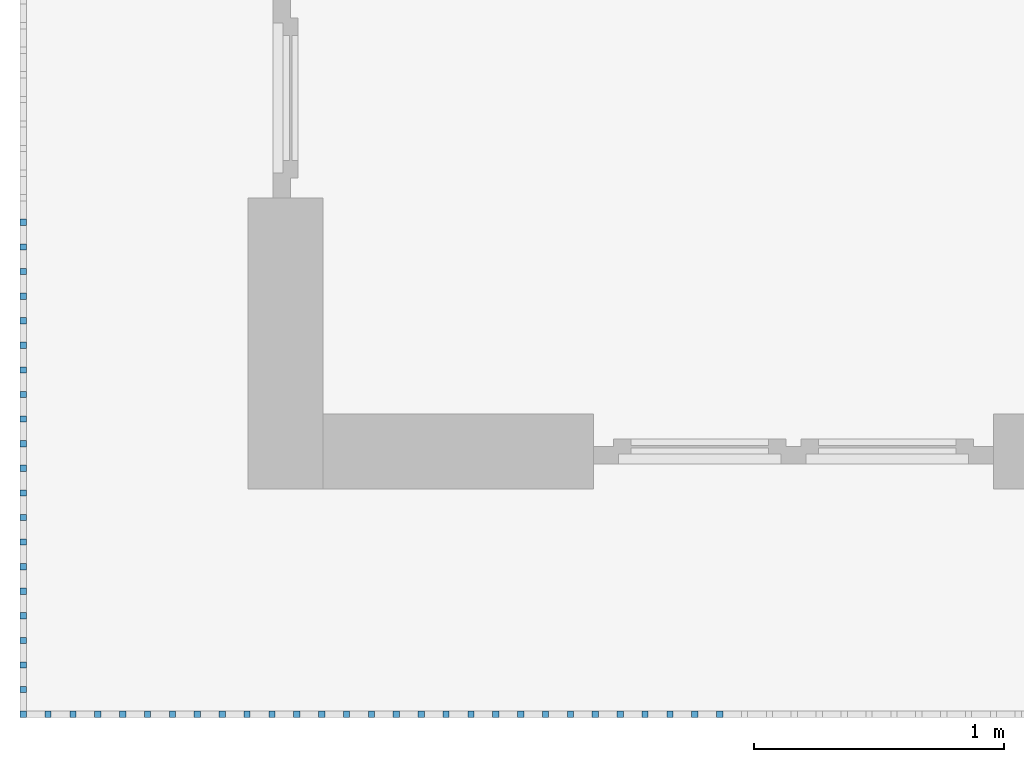
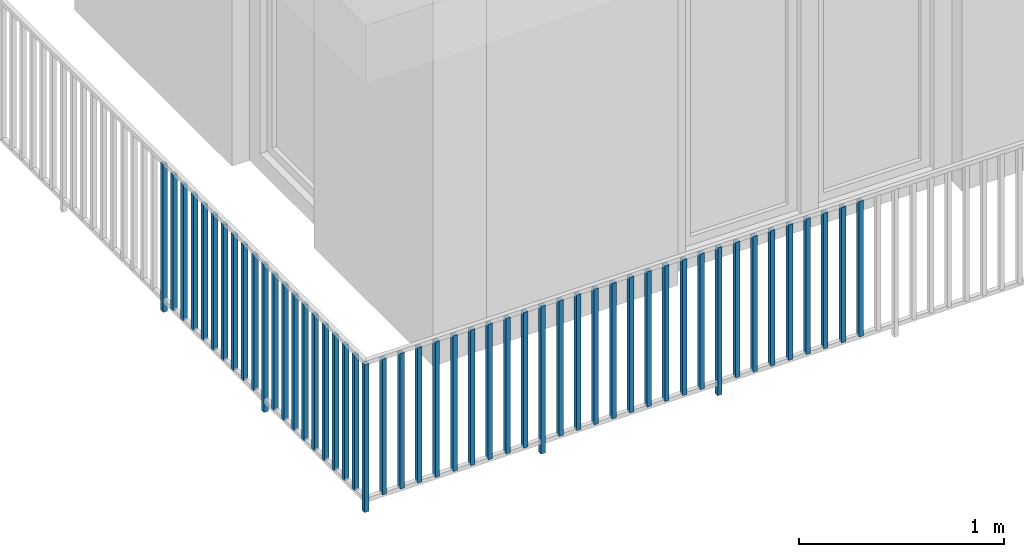
# One storey, part 31 of 54: 49 building element parts, 1 element without a shape of its own.
"""IFC4 building model written with IfcOpenShell, lengths in metres."""

from ifc_helpers import new_model, entity, si_unit, converted_unit, derived_unit, direction, frame, origin_with_axes, place, context, subcontext, project, spatial, polygons, material, type_object, element, aggregate, save


model = new_model("IFC4")

# Units and contexts
model_context = context("Model", 3, precision=1e-05, world=origin_with_axes(), true_north=direction((0.0, 1.0)))
body_context = subcontext(model_context, "Body", "Model", "MODEL_VIEW")
ifc_project = project(units=[si_unit("LENGTHUNIT", "METRE"), si_unit("AREAUNIT", "SQUARE_METRE"), si_unit("VOLUMEUNIT", "CUBIC_METRE"), converted_unit("PLANEANGLEUNIT", "DEGREE", entity("IfcPlaneAngleMeasure", 0.0174532925199), si_unit("PLANEANGLEUNIT", "RADIAN"), dimensions=[0, 0, 0, 0, 0, 0, 0]), converted_unit("TIMEUNIT", "Year", entity("IfcTimeMeasure", 31556926.0), si_unit("TIMEUNIT", "SECOND"), dimensions=[0, 0, 1, 0, 0, 0, 0]), si_unit("MASSUNIT", "GRAM", prefix="KILO"), si_unit("THERMODYNAMICTEMPERATUREUNIT", "DEGREE_CELSIUS"), si_unit("LUMINOUSINTENSITYUNIT", "LUMEN"), si_unit("ENERGYUNIT", "JOULE", prefix="MEGA"), derived_unit("THERMALCONDUCTANCEUNIT", [(si_unit("POWERUNIT", "WATT"), 1), (si_unit("LENGTHUNIT", "METRE"), -1), (si_unit("THERMODYNAMICTEMPERATUREUNIT", "KELVIN"), -1)]), derived_unit("SPECIFICHEATCAPACITYUNIT", [(si_unit("ENERGYUNIT", "JOULE"), 1), (si_unit("MASSUNIT", "GRAM", prefix="KILO"), -1), (si_unit("THERMODYNAMICTEMPERATUREUNIT", "KELVIN"), -1)]), derived_unit("MASSDENSITYUNIT", [(si_unit("MASSUNIT", "GRAM", prefix="KILO"), 1), (si_unit("VOLUMEUNIT", "CUBIC_METRE"), -1)])], contexts=[model_context])

# Site, building, storey, space
site_placement = place(None, origin_with_axes())
site = spatial("IfcSite", under=ifc_project, at=site_placement, CompositionType="ELEMENT")
building_placement = place(site_placement, origin_with_axes())
building = spatial("IfcBuilding", under=site, at=building_placement, CompositionType="ELEMENT")
storey_placement = place(building_placement, frame((0.0, 0.0, 6.29), z_axis=(0.0, 0.0, 1.0), x_axis=(1.0, 0.0, 0.0)))
storey = spatial("IfcBuildingStorey", under=building, at=storey_placement, Name="2. Geschoss", CompositionType="ELEMENT", Elevation=6.29)
space_placement = place(storey_placement, frame((10.2378006196, 9.82118769833, 0.0), z_axis=(0.0, 0.0, 1.0), x_axis=(-1.0, 0.0, 0.0)))
space = spatial("IfcSpace", under=storey, at=space_placement, CompositionType="ELEMENT", PredefinedType="EXTERNAL")

# Railing, building element parts
railing_type = type_object("IfcRailingType", PredefinedType="NOTDEFINED")
railing_placement = place(space_placement, frame((0.0, -7.06315681498e-08, 0.0), z_axis=(0.0, 0.0, 1.0), x_axis=(-1.0, 0.0, 0.0)))
railing = element("IfcRailing", 1, at=railing_placement, inside=space, type_object=railing_type, PredefinedType="NOTDEFINED")
ifc_material = material()
building_element_part_1_placement = place(railing_placement, origin_with_axes())
building_element_part_1 = element("IfcBuildingElementPart", 2, at=building_element_part_1_placement, material=ifc_material, PredefinedType="NOTDEFINED", context=body_context, shape_type="Tessellation", body=[
    polygons([(-22.8925, -20.6625, 0.0), (-22.8675, -20.6625, 0.0), (-22.8675, -20.6625, 0.88), (-22.8925, -20.6625, 0.88), (-22.8925, -20.6375, 0.0), (-22.8675, -20.6375, 0.0), (-22.8675, -20.6375, 0.88), (-22.8925, -20.6375, 0.88)], [[[1, 2, 3, 4]], [[1, 5, 6, 2]], [[2, 6, 7, 3]], [[4, 3, 7, 8]], [[5, 1, 4, 8]], [[6, 5, 8, 7]]], closed=True),
])
building_element_part_2_placement = place(railing_placement, origin_with_axes())
building_element_part_2 = element("IfcBuildingElementPart", 3, at=building_element_part_2_placement, material=ifc_material, PredefinedType="NOTDEFINED", context=body_context, shape_type="Tessellation", body=[
    polygons([(-22.8925, -18.6958333333, 0.0), (-22.8675, -18.6958333333, 0.0), (-22.8675, -18.6958333333, 0.88), (-22.8925, -18.6958333333, 0.88), (-22.8925, -18.6708333333, 0.0), (-22.8675, -18.6708333333, 0.0), (-22.8675, -18.6708333333, 0.88), (-22.8925, -18.6708333333, 0.88)], [[[1, 2, 3, 4]], [[1, 5, 6, 2]], [[2, 6, 7, 3]], [[4, 3, 7, 8]], [[5, 1, 4, 8]], [[6, 5, 8, 7]]], closed=True),
])
building_element_part_3_placement = place(railing_placement, origin_with_axes())
building_element_part_3 = element("IfcBuildingElementPart", 4, at=building_element_part_3_placement, material=ifc_material, PredefinedType="NOTDEFINED", context=body_context, shape_type="Tessellation", body=[
    polygons([(-22.8925, -18.7941666667, 0.07), (-22.8675, -18.7941666667, 0.07), (-22.8675, -18.7941666667, 0.8775), (-22.8925, -18.7941666667, 0.8775), (-22.8925, -18.7691666667, 0.07), (-22.8675, -18.7691666667, 0.07), (-22.8675, -18.7691666667, 0.8775), (-22.8925, -18.7691666667, 0.8775)], [[[1, 2, 3, 4]], [[1, 5, 6, 2]], [[2, 6, 7, 3]], [[4, 3, 7, 8]], [[5, 1, 4, 8]], [[6, 5, 8, 7]]], closed=True),
])
building_element_part_4_placement = place(railing_placement, origin_with_axes())
building_element_part_4 = element("IfcBuildingElementPart", 5, at=building_element_part_4_placement, material=ifc_material, PredefinedType="NOTDEFINED", context=body_context, shape_type="Tessellation", body=[
    polygons([(-22.8925, -18.8925, 0.07), (-22.8675, -18.8925, 0.07), (-22.8675, -18.8925, 0.8775), (-22.8925, -18.8925, 0.8775), (-22.8925, -18.8675, 0.07), (-22.8675, -18.8675, 0.07), (-22.8675, -18.8675, 0.8775), (-22.8925, -18.8675, 0.8775)], [[[1, 2, 3, 4]], [[1, 5, 6, 2]], [[2, 6, 7, 3]], [[4, 3, 7, 8]], [[5, 1, 4, 8]], [[6, 5, 8, 7]]], closed=True),
])
building_element_part_5_placement = place(railing_placement, origin_with_axes())
building_element_part_5 = element("IfcBuildingElementPart", 6, at=building_element_part_5_placement, material=ifc_material, PredefinedType="NOTDEFINED", context=body_context, shape_type="Tessellation", body=[
    polygons([(-22.8925, -18.9908333333, 0.07), (-22.8675, -18.9908333333, 0.07), (-22.8675, -18.9908333333, 0.8775), (-22.8925, -18.9908333333, 0.8775), (-22.8925, -18.9658333333, 0.07), (-22.8675, -18.9658333333, 0.07), (-22.8675, -18.9658333333, 0.8775), (-22.8925, -18.9658333333, 0.8775)], [[[1, 2, 3, 4]], [[1, 5, 6, 2]], [[2, 6, 7, 3]], [[4, 3, 7, 8]], [[5, 1, 4, 8]], [[6, 5, 8, 7]]], closed=True),
])
building_element_part_6_placement = place(railing_placement, origin_with_axes())
building_element_part_6 = element("IfcBuildingElementPart", 7, at=building_element_part_6_placement, material=ifc_material, PredefinedType="NOTDEFINED", context=body_context, shape_type="Tessellation", body=[
    polygons([(-22.8925, -19.0891666667, 0.07), (-22.8675, -19.0891666667, 0.07), (-22.8675, -19.0891666667, 0.8775), (-22.8925, -19.0891666667, 0.8775), (-22.8925, -19.0641666667, 0.07), (-22.8675, -19.0641666667, 0.07), (-22.8675, -19.0641666667, 0.8775), (-22.8925, -19.0641666667, 0.8775)], [[[1, 2, 3, 4]], [[1, 5, 6, 2]], [[2, 6, 7, 3]], [[4, 3, 7, 8]], [[5, 1, 4, 8]], [[6, 5, 8, 7]]], closed=True),
])
building_element_part_7_placement = place(railing_placement, origin_with_axes())
building_element_part_7 = element("IfcBuildingElementPart", 8, at=building_element_part_7_placement, material=ifc_material, PredefinedType="NOTDEFINED", context=body_context, shape_type="Tessellation", body=[
    polygons([(-22.8925, -19.1875, 0.07), (-22.8675, -19.1875, 0.07), (-22.8675, -19.1875, 0.8775), (-22.8925, -19.1875, 0.8775), (-22.8925, -19.1625, 0.07), (-22.8675, -19.1625, 0.07), (-22.8675, -19.1625, 0.8775), (-22.8925, -19.1625, 0.8775)], [[[1, 2, 3, 4]], [[1, 5, 6, 2]], [[2, 6, 7, 3]], [[4, 3, 7, 8]], [[5, 1, 4, 8]], [[6, 5, 8, 7]]], closed=True),
])
building_element_part_8_placement = place(railing_placement, origin_with_axes())
building_element_part_8 = element("IfcBuildingElementPart", 9, at=building_element_part_8_placement, material=ifc_material, PredefinedType="NOTDEFINED", context=body_context, shape_type="Tessellation", body=[
    polygons([(-22.8925, -19.2858333333, 0.07), (-22.8675, -19.2858333333, 0.07), (-22.8675, -19.2858333333, 0.8775), (-22.8925, -19.2858333333, 0.8775), (-22.8925, -19.2608333333, 0.07), (-22.8675, -19.2608333333, 0.07), (-22.8675, -19.2608333333, 0.8775), (-22.8925, -19.2608333333, 0.8775)], [[[1, 2, 3, 4]], [[1, 5, 6, 2]], [[2, 6, 7, 3]], [[4, 3, 7, 8]], [[5, 1, 4, 8]], [[6, 5, 8, 7]]], closed=True),
])
building_element_part_9_placement = place(railing_placement, origin_with_axes())
building_element_part_9 = element("IfcBuildingElementPart", 10, at=building_element_part_9_placement, material=ifc_material, PredefinedType="NOTDEFINED", context=body_context, shape_type="Tessellation", body=[
    polygons([(-22.8925, -19.3841666667, 0.07), (-22.8675, -19.3841666667, 0.07), (-22.8675, -19.3841666667, 0.8775), (-22.8925, -19.3841666667, 0.8775), (-22.8925, -19.3591666667, 0.07), (-22.8675, -19.3591666667, 0.07), (-22.8675, -19.3591666667, 0.8775), (-22.8925, -19.3591666667, 0.8775)], [[[1, 2, 3, 4]], [[1, 5, 6, 2]], [[2, 6, 7, 3]], [[4, 3, 7, 8]], [[5, 1, 4, 8]], [[6, 5, 8, 7]]], closed=True),
])
building_element_part_10_placement = place(railing_placement, origin_with_axes())
building_element_part_10 = element("IfcBuildingElementPart", 11, at=building_element_part_10_placement, material=ifc_material, PredefinedType="NOTDEFINED", context=body_context, shape_type="Tessellation", body=[
    polygons([(-22.8925, -19.4825, 0.07), (-22.8675, -19.4825, 0.07), (-22.8675, -19.4825, 0.8775), (-22.8925, -19.4825, 0.8775), (-22.8925, -19.4575, 0.07), (-22.8675, -19.4575, 0.07), (-22.8675, -19.4575, 0.8775), (-22.8925, -19.4575, 0.8775)], [[[1, 2, 3, 4]], [[1, 5, 6, 2]], [[2, 6, 7, 3]], [[4, 3, 7, 8]], [[5, 1, 4, 8]], [[6, 5, 8, 7]]], closed=True),
])
building_element_part_11_placement = place(railing_placement, origin_with_axes())
building_element_part_11 = element("IfcBuildingElementPart", 12, at=building_element_part_11_placement, material=ifc_material, PredefinedType="NOTDEFINED", context=body_context, shape_type="Tessellation", body=[
    polygons([(-22.8925, -19.5808333333, 0.07), (-22.8675, -19.5808333333, 0.07), (-22.8675, -19.5808333333, 0.8775), (-22.8925, -19.5808333333, 0.8775), (-22.8925, -19.5558333333, 0.07), (-22.8675, -19.5558333333, 0.07), (-22.8675, -19.5558333333, 0.8775), (-22.8925, -19.5558333333, 0.8775)], [[[1, 2, 3, 4]], [[1, 5, 6, 2]], [[2, 6, 7, 3]], [[4, 3, 7, 8]], [[5, 1, 4, 8]], [[6, 5, 8, 7]]], closed=True),
])
building_element_part_12_placement = place(railing_placement, origin_with_axes())
building_element_part_12 = element("IfcBuildingElementPart", 13, at=building_element_part_12_placement, material=ifc_material, PredefinedType="NOTDEFINED", context=body_context, shape_type="Tessellation", body=[
    polygons([(-22.8925, -19.6791666667, 0.0), (-22.8675, -19.6791666667, 0.0), (-22.8675, -19.6791666667, 0.88), (-22.8925, -19.6791666667, 0.88), (-22.8925, -19.6541666667, 0.0), (-22.8675, -19.6541666667, 0.0), (-22.8675, -19.6541666667, 0.88), (-22.8925, -19.6541666667, 0.88)], [[[1, 2, 3, 4]], [[1, 5, 6, 2]], [[2, 6, 7, 3]], [[4, 3, 7, 8]], [[5, 1, 4, 8]], [[6, 5, 8, 7]]], closed=True),
])
building_element_part_13_placement = place(railing_placement, origin_with_axes())
building_element_part_13 = element("IfcBuildingElementPart", 14, at=building_element_part_13_placement, material=ifc_material, PredefinedType="NOTDEFINED", context=body_context, shape_type="Tessellation", body=[
    polygons([(-22.8925, -19.7775, 0.07), (-22.8675, -19.7775, 0.07), (-22.8675, -19.7775, 0.8775), (-22.8925, -19.7775, 0.8775), (-22.8925, -19.7525, 0.07), (-22.8675, -19.7525, 0.07), (-22.8675, -19.7525, 0.8775), (-22.8925, -19.7525, 0.8775)], [[[1, 2, 3, 4]], [[1, 5, 6, 2]], [[2, 6, 7, 3]], [[4, 3, 7, 8]], [[5, 1, 4, 8]], [[6, 5, 8, 7]]], closed=True),
])
building_element_part_14_placement = place(railing_placement, origin_with_axes())
building_element_part_14 = element("IfcBuildingElementPart", 15, at=building_element_part_14_placement, material=ifc_material, PredefinedType="NOTDEFINED", context=body_context, shape_type="Tessellation", body=[
    polygons([(-22.8925, -19.8758333333, 0.07), (-22.8675, -19.8758333333, 0.07), (-22.8675, -19.8758333333, 0.8775), (-22.8925, -19.8758333333, 0.8775), (-22.8925, -19.8508333333, 0.07), (-22.8675, -19.8508333333, 0.07), (-22.8675, -19.8508333333, 0.8775), (-22.8925, -19.8508333333, 0.8775)], [[[1, 2, 3, 4]], [[1, 5, 6, 2]], [[2, 6, 7, 3]], [[4, 3, 7, 8]], [[5, 1, 4, 8]], [[6, 5, 8, 7]]], closed=True),
])
building_element_part_15_placement = place(railing_placement, origin_with_axes())
building_element_part_15 = element("IfcBuildingElementPart", 16, at=building_element_part_15_placement, material=ifc_material, PredefinedType="NOTDEFINED", context=body_context, shape_type="Tessellation", body=[
    polygons([(-22.8925, -19.9741666667, 0.07), (-22.8675, -19.9741666667, 0.07), (-22.8675, -19.9741666667, 0.8775), (-22.8925, -19.9741666667, 0.8775), (-22.8925, -19.9491666667, 0.07), (-22.8675, -19.9491666667, 0.07), (-22.8675, -19.9491666667, 0.8775), (-22.8925, -19.9491666667, 0.8775)], [[[1, 2, 3, 4]], [[1, 5, 6, 2]], [[2, 6, 7, 3]], [[4, 3, 7, 8]], [[5, 1, 4, 8]], [[6, 5, 8, 7]]], closed=True),
])
building_element_part_16_placement = place(railing_placement, origin_with_axes())
building_element_part_16 = element("IfcBuildingElementPart", 17, at=building_element_part_16_placement, material=ifc_material, PredefinedType="NOTDEFINED", context=body_context, shape_type="Tessellation", body=[
    polygons([(-22.8925, -20.0725, 0.07), (-22.8675, -20.0725, 0.07), (-22.8675, -20.0725, 0.8775), (-22.8925, -20.0725, 0.8775), (-22.8925, -20.0475, 0.07), (-22.8675, -20.0475, 0.07), (-22.8675, -20.0475, 0.8775), (-22.8925, -20.0475, 0.8775)], [[[1, 2, 3, 4]], [[1, 5, 6, 2]], [[2, 6, 7, 3]], [[4, 3, 7, 8]], [[5, 1, 4, 8]], [[6, 5, 8, 7]]], closed=True),
])
building_element_part_17_placement = place(railing_placement, origin_with_axes())
building_element_part_17 = element("IfcBuildingElementPart", 18, at=building_element_part_17_placement, material=ifc_material, PredefinedType="NOTDEFINED", context=body_context, shape_type="Tessellation", body=[
    polygons([(-22.8925, -20.1708333333, 0.07), (-22.8675, -20.1708333333, 0.07), (-22.8675, -20.1708333333, 0.8775), (-22.8925, -20.1708333333, 0.8775), (-22.8925, -20.1458333333, 0.07), (-22.8675, -20.1458333333, 0.07), (-22.8675, -20.1458333333, 0.8775), (-22.8925, -20.1458333333, 0.8775)], [[[1, 2, 3, 4]], [[1, 5, 6, 2]], [[2, 6, 7, 3]], [[4, 3, 7, 8]], [[5, 1, 4, 8]], [[6, 5, 8, 7]]], closed=True),
])
building_element_part_18_placement = place(railing_placement, origin_with_axes())
building_element_part_18 = element("IfcBuildingElementPart", 19, at=building_element_part_18_placement, material=ifc_material, PredefinedType="NOTDEFINED", context=body_context, shape_type="Tessellation", body=[
    polygons([(-22.8925, -20.2691666667, 0.07), (-22.8675, -20.2691666667, 0.07), (-22.8675, -20.2691666667, 0.8775), (-22.8925, -20.2691666667, 0.8775), (-22.8925, -20.2441666667, 0.07), (-22.8675, -20.2441666667, 0.07), (-22.8675, -20.2441666667, 0.8775), (-22.8925, -20.2441666667, 0.8775)], [[[1, 2, 3, 4]], [[1, 5, 6, 2]], [[2, 6, 7, 3]], [[4, 3, 7, 8]], [[5, 1, 4, 8]], [[6, 5, 8, 7]]], closed=True),
])
building_element_part_19_placement = place(railing_placement, origin_with_axes())
building_element_part_19 = element("IfcBuildingElementPart", 20, at=building_element_part_19_placement, material=ifc_material, PredefinedType="NOTDEFINED", context=body_context, shape_type="Tessellation", body=[
    polygons([(-22.8925, -20.3675, 0.07), (-22.8675, -20.3675, 0.07), (-22.8675, -20.3675, 0.8775), (-22.8925, -20.3675, 0.8775), (-22.8925, -20.3425, 0.07), (-22.8675, -20.3425, 0.07), (-22.8675, -20.3425, 0.8775), (-22.8925, -20.3425, 0.8775)], [[[1, 2, 3, 4]], [[1, 5, 6, 2]], [[2, 6, 7, 3]], [[4, 3, 7, 8]], [[5, 1, 4, 8]], [[6, 5, 8, 7]]], closed=True),
])
building_element_part_20_placement = place(railing_placement, origin_with_axes())
building_element_part_20 = element("IfcBuildingElementPart", 21, at=building_element_part_20_placement, material=ifc_material, PredefinedType="NOTDEFINED", context=body_context, shape_type="Tessellation", body=[
    polygons([(-22.8925, -20.4658333333, 0.07), (-22.8675, -20.4658333333, 0.07), (-22.8675, -20.4658333333, 0.8775), (-22.8925, -20.4658333333, 0.8775), (-22.8925, -20.4408333333, 0.07), (-22.8675, -20.4408333333, 0.07), (-22.8675, -20.4408333333, 0.8775), (-22.8925, -20.4408333333, 0.8775)], [[[1, 2, 3, 4]], [[1, 5, 6, 2]], [[2, 6, 7, 3]], [[4, 3, 7, 8]], [[5, 1, 4, 8]], [[6, 5, 8, 7]]], closed=True),
])
building_element_part_21_placement = place(railing_placement, origin_with_axes())
building_element_part_21 = element("IfcBuildingElementPart", 22, at=building_element_part_21_placement, material=ifc_material, PredefinedType="NOTDEFINED", context=body_context, shape_type="Tessellation", body=[
    polygons([(-22.8925, -20.5641666667, 0.07), (-22.8675, -20.5641666667, 0.07), (-22.8675, -20.5641666667, 0.8775), (-22.8925, -20.5641666667, 0.8775), (-22.8925, -20.5391666667, 0.07), (-22.8675, -20.5391666667, 0.07), (-22.8675, -20.5391666667, 0.8775), (-22.8925, -20.5391666667, 0.8775)], [[[1, 2, 3, 4]], [[1, 5, 6, 2]], [[2, 6, 7, 3]], [[4, 3, 7, 8]], [[5, 1, 4, 8]], [[6, 5, 8, 7]]], closed=True),
])
building_element_part_22_placement = place(railing_placement, origin_with_axes())
building_element_part_22 = element("IfcBuildingElementPart", 23, at=building_element_part_22_placement, material=ifc_material, PredefinedType="NOTDEFINED", context=body_context, shape_type="Tessellation", body=[
    polygons([(-22.7680217391, -20.6625, 0.07), (-22.7680217391, -20.6375, 0.07), (-22.7680217391, -20.6375, 0.8775), (-22.7680217391, -20.6625, 0.8775), (-22.7930217391, -20.6625, 0.07), (-22.7930217391, -20.6375, 0.07), (-22.7930217391, -20.6375, 0.8775), (-22.7930217391, -20.6625, 0.8775)], [[[1, 2, 3, 4]], [[1, 5, 6, 2]], [[2, 6, 7, 3]], [[4, 3, 7, 8]], [[5, 1, 4, 8]], [[6, 5, 8, 7]]], closed=True),
])
building_element_part_23_placement = place(railing_placement, origin_with_axes())
building_element_part_23 = element("IfcBuildingElementPart", 24, at=building_element_part_23_placement, material=ifc_material, PredefinedType="NOTDEFINED", context=body_context, shape_type="Tessellation", body=[
    polygons([(-22.6685434783, -20.6625, 0.07), (-22.6685434783, -20.6375, 0.07), (-22.6685434783, -20.6375, 0.8775), (-22.6685434783, -20.6625, 0.8775), (-22.6935434783, -20.6625, 0.07), (-22.6935434783, -20.6375, 0.07), (-22.6935434783, -20.6375, 0.8775), (-22.6935434783, -20.6625, 0.8775)], [[[1, 2, 3, 4]], [[1, 5, 6, 2]], [[2, 6, 7, 3]], [[4, 3, 7, 8]], [[5, 1, 4, 8]], [[6, 5, 8, 7]]], closed=True),
])
building_element_part_24_placement = place(railing_placement, origin_with_axes())
building_element_part_24 = element("IfcBuildingElementPart", 25, at=building_element_part_24_placement, material=ifc_material, PredefinedType="NOTDEFINED", context=body_context, shape_type="Tessellation", body=[
    polygons([(-22.5690652174, -20.6625, 0.07), (-22.5690652174, -20.6375, 0.07), (-22.5690652174, -20.6375, 0.8775), (-22.5690652174, -20.6625, 0.8775), (-22.5940652174, -20.6625, 0.07), (-22.5940652174, -20.6375, 0.07), (-22.5940652174, -20.6375, 0.8775), (-22.5940652174, -20.6625, 0.8775)], [[[1, 2, 3, 4]], [[1, 5, 6, 2]], [[2, 6, 7, 3]], [[4, 3, 7, 8]], [[5, 1, 4, 8]], [[6, 5, 8, 7]]], closed=True),
])
building_element_part_25_placement = place(railing_placement, origin_with_axes())
building_element_part_25 = element("IfcBuildingElementPart", 26, at=building_element_part_25_placement, material=ifc_material, PredefinedType="NOTDEFINED", context=body_context, shape_type="Tessellation", body=[
    polygons([(-22.4695869565, -20.6625, 0.07), (-22.4695869565, -20.6375, 0.07), (-22.4695869565, -20.6375, 0.8775), (-22.4695869565, -20.6625, 0.8775), (-22.4945869565, -20.6625, 0.07), (-22.4945869565, -20.6375, 0.07), (-22.4945869565, -20.6375, 0.8775), (-22.4945869565, -20.6625, 0.8775)], [[[1, 2, 3, 4]], [[1, 5, 6, 2]], [[2, 6, 7, 3]], [[4, 3, 7, 8]], [[5, 1, 4, 8]], [[6, 5, 8, 7]]], closed=True),
])
building_element_part_26_placement = place(railing_placement, origin_with_axes())
building_element_part_26 = element("IfcBuildingElementPart", 27, at=building_element_part_26_placement, material=ifc_material, PredefinedType="NOTDEFINED", context=body_context, shape_type="Tessellation", body=[
    polygons([(-22.3701086957, -20.6625, 0.07), (-22.3701086957, -20.6375, 0.07), (-22.3701086957, -20.6375, 0.8775), (-22.3701086957, -20.6625, 0.8775), (-22.3951086957, -20.6625, 0.07), (-22.3951086957, -20.6375, 0.07), (-22.3951086957, -20.6375, 0.8775), (-22.3951086957, -20.6625, 0.8775)], [[[1, 2, 3, 4]], [[1, 5, 6, 2]], [[2, 6, 7, 3]], [[4, 3, 7, 8]], [[5, 1, 4, 8]], [[6, 5, 8, 7]]], closed=True),
])
building_element_part_27_placement = place(railing_placement, origin_with_axes())
building_element_part_27 = element("IfcBuildingElementPart", 28, at=building_element_part_27_placement, material=ifc_material, PredefinedType="NOTDEFINED", context=body_context, shape_type="Tessellation", body=[
    polygons([(-22.2706304348, -20.6625, 0.07), (-22.2706304348, -20.6375, 0.07), (-22.2706304348, -20.6375, 0.8775), (-22.2706304348, -20.6625, 0.8775), (-22.2956304348, -20.6625, 0.07), (-22.2956304348, -20.6375, 0.07), (-22.2956304348, -20.6375, 0.8775), (-22.2956304348, -20.6625, 0.8775)], [[[1, 2, 3, 4]], [[1, 5, 6, 2]], [[2, 6, 7, 3]], [[4, 3, 7, 8]], [[5, 1, 4, 8]], [[6, 5, 8, 7]]], closed=True),
])
building_element_part_28_placement = place(railing_placement, origin_with_axes())
building_element_part_28 = element("IfcBuildingElementPart", 29, at=building_element_part_28_placement, material=ifc_material, PredefinedType="NOTDEFINED", context=body_context, shape_type="Tessellation", body=[
    polygons([(-22.1711521739, -20.6625, 0.07), (-22.1711521739, -20.6375, 0.07), (-22.1711521739, -20.6375, 0.8775), (-22.1711521739, -20.6625, 0.8775), (-22.1961521739, -20.6625, 0.07), (-22.1961521739, -20.6375, 0.07), (-22.1961521739, -20.6375, 0.8775), (-22.1961521739, -20.6625, 0.8775)], [[[1, 2, 3, 4]], [[1, 5, 6, 2]], [[2, 6, 7, 3]], [[4, 3, 7, 8]], [[5, 1, 4, 8]], [[6, 5, 8, 7]]], closed=True),
])
building_element_part_29_placement = place(railing_placement, origin_with_axes())
building_element_part_29 = element("IfcBuildingElementPart", 30, at=building_element_part_29_placement, material=ifc_material, PredefinedType="NOTDEFINED", context=body_context, shape_type="Tessellation", body=[
    polygons([(-22.071673913, -20.6625, 0.07), (-22.071673913, -20.6375, 0.07), (-22.071673913, -20.6375, 0.8775), (-22.071673913, -20.6625, 0.8775), (-22.096673913, -20.6625, 0.07), (-22.096673913, -20.6375, 0.07), (-22.096673913, -20.6375, 0.8775), (-22.096673913, -20.6625, 0.8775)], [[[1, 2, 3, 4]], [[1, 5, 6, 2]], [[2, 6, 7, 3]], [[4, 3, 7, 8]], [[5, 1, 4, 8]], [[6, 5, 8, 7]]], closed=True),
])
building_element_part_30_placement = place(railing_placement, origin_with_axes())
building_element_part_30 = element("IfcBuildingElementPart", 31, at=building_element_part_30_placement, material=ifc_material, PredefinedType="NOTDEFINED", context=body_context, shape_type="Tessellation", body=[
    polygons([(-21.9721956522, -20.6625, 0.07), (-21.9721956522, -20.6375, 0.07), (-21.9721956522, -20.6375, 0.8775), (-21.9721956522, -20.6625, 0.8775), (-21.9971956522, -20.6625, 0.07), (-21.9971956522, -20.6375, 0.07), (-21.9971956522, -20.6375, 0.8775), (-21.9971956522, -20.6625, 0.8775)], [[[1, 2, 3, 4]], [[1, 5, 6, 2]], [[2, 6, 7, 3]], [[4, 3, 7, 8]], [[5, 1, 4, 8]], [[6, 5, 8, 7]]], closed=True),
])
building_element_part_31_placement = place(railing_placement, origin_with_axes())
building_element_part_31 = element("IfcBuildingElementPart", 32, at=building_element_part_31_placement, material=ifc_material, PredefinedType="NOTDEFINED", context=body_context, shape_type="Tessellation", body=[
    polygons([(-21.8727173913, -20.6625, 0.0), (-21.8727173913, -20.6375, 0.0), (-21.8727173913, -20.6375, 0.88), (-21.8727173913, -20.6625, 0.88), (-21.8977173913, -20.6625, 0.0), (-21.8977173913, -20.6375, 0.0), (-21.8977173913, -20.6375, 0.88), (-21.8977173913, -20.6625, 0.88)], [[[1, 2, 3, 4]], [[1, 5, 6, 2]], [[2, 6, 7, 3]], [[4, 3, 7, 8]], [[5, 1, 4, 8]], [[6, 5, 8, 7]]], closed=True),
])
building_element_part_32_placement = place(railing_placement, origin_with_axes())
building_element_part_32 = element("IfcBuildingElementPart", 33, at=building_element_part_32_placement, material=ifc_material, PredefinedType="NOTDEFINED", context=body_context, shape_type="Tessellation", body=[
    polygons([(-21.7732391304, -20.6625, 0.07), (-21.7732391304, -20.6375, 0.07), (-21.7732391304, -20.6375, 0.8775), (-21.7732391304, -20.6625, 0.8775), (-21.7982391304, -20.6625, 0.07), (-21.7982391304, -20.6375, 0.07), (-21.7982391304, -20.6375, 0.8775), (-21.7982391304, -20.6625, 0.8775)], [[[1, 2, 3, 4]], [[1, 5, 6, 2]], [[2, 6, 7, 3]], [[4, 3, 7, 8]], [[5, 1, 4, 8]], [[6, 5, 8, 7]]], closed=True),
])
building_element_part_33_placement = place(railing_placement, origin_with_axes())
building_element_part_33 = element("IfcBuildingElementPart", 34, at=building_element_part_33_placement, material=ifc_material, PredefinedType="NOTDEFINED", context=body_context, shape_type="Tessellation", body=[
    polygons([(-21.6737608696, -20.6625, 0.07), (-21.6737608696, -20.6375, 0.07), (-21.6737608696, -20.6375, 0.8775), (-21.6737608696, -20.6625, 0.8775), (-21.6987608696, -20.6625, 0.07), (-21.6987608696, -20.6375, 0.07), (-21.6987608696, -20.6375, 0.8775), (-21.6987608696, -20.6625, 0.8775)], [[[1, 2, 3, 4]], [[1, 5, 6, 2]], [[2, 6, 7, 3]], [[4, 3, 7, 8]], [[5, 1, 4, 8]], [[6, 5, 8, 7]]], closed=True),
])
building_element_part_34_placement = place(railing_placement, origin_with_axes())
building_element_part_34 = element("IfcBuildingElementPart", 35, at=building_element_part_34_placement, material=ifc_material, PredefinedType="NOTDEFINED", context=body_context, shape_type="Tessellation", body=[
    polygons([(-21.5742826087, -20.6625, 0.07), (-21.5742826087, -20.6375, 0.07), (-21.5742826087, -20.6375, 0.8775), (-21.5742826087, -20.6625, 0.8775), (-21.5992826087, -20.6625, 0.07), (-21.5992826087, -20.6375, 0.07), (-21.5992826087, -20.6375, 0.8775), (-21.5992826087, -20.6625, 0.8775)], [[[1, 2, 3, 4]], [[1, 5, 6, 2]], [[2, 6, 7, 3]], [[4, 3, 7, 8]], [[5, 1, 4, 8]], [[6, 5, 8, 7]]], closed=True),
])
building_element_part_35_placement = place(railing_placement, origin_with_axes())
building_element_part_35 = element("IfcBuildingElementPart", 36, at=building_element_part_35_placement, material=ifc_material, PredefinedType="NOTDEFINED", context=body_context, shape_type="Tessellation", body=[
    polygons([(-21.4748043478, -20.6625, 0.07), (-21.4748043478, -20.6375, 0.07), (-21.4748043478, -20.6375, 0.8775), (-21.4748043478, -20.6625, 0.8775), (-21.4998043478, -20.6625, 0.07), (-21.4998043478, -20.6375, 0.07), (-21.4998043478, -20.6375, 0.8775), (-21.4998043478, -20.6625, 0.8775)], [[[1, 2, 3, 4]], [[1, 5, 6, 2]], [[2, 6, 7, 3]], [[4, 3, 7, 8]], [[5, 1, 4, 8]], [[6, 5, 8, 7]]], closed=True),
])
building_element_part_36_placement = place(railing_placement, origin_with_axes())
building_element_part_36 = element("IfcBuildingElementPart", 37, at=building_element_part_36_placement, material=ifc_material, PredefinedType="NOTDEFINED", context=body_context, shape_type="Tessellation", body=[
    polygons([(-21.375326087, -20.6625, 0.07), (-21.375326087, -20.6375, 0.07), (-21.375326087, -20.6375, 0.8775), (-21.375326087, -20.6625, 0.8775), (-21.400326087, -20.6625, 0.07), (-21.400326087, -20.6375, 0.07), (-21.400326087, -20.6375, 0.8775), (-21.400326087, -20.6625, 0.8775)], [[[1, 2, 3, 4]], [[1, 5, 6, 2]], [[2, 6, 7, 3]], [[4, 3, 7, 8]], [[5, 1, 4, 8]], [[6, 5, 8, 7]]], closed=True),
])
building_element_part_37_placement = place(railing_placement, origin_with_axes())
building_element_part_37 = element("IfcBuildingElementPart", 38, at=building_element_part_37_placement, material=ifc_material, PredefinedType="NOTDEFINED", context=body_context, shape_type="Tessellation", body=[
    polygons([(-21.2758478261, -20.6625, 0.07), (-21.2758478261, -20.6375, 0.07), (-21.2758478261, -20.6375, 0.8775), (-21.2758478261, -20.6625, 0.8775), (-21.3008478261, -20.6625, 0.07), (-21.3008478261, -20.6375, 0.07), (-21.3008478261, -20.6375, 0.8775), (-21.3008478261, -20.6625, 0.8775)], [[[1, 2, 3, 4]], [[1, 5, 6, 2]], [[2, 6, 7, 3]], [[4, 3, 7, 8]], [[5, 1, 4, 8]], [[6, 5, 8, 7]]], closed=True),
])
building_element_part_38_placement = place(railing_placement, origin_with_axes())
building_element_part_38 = element("IfcBuildingElementPart", 39, at=building_element_part_38_placement, material=ifc_material, PredefinedType="NOTDEFINED", context=body_context, shape_type="Tessellation", body=[
    polygons([(-21.1763695652, -20.6625, 0.07), (-21.1763695652, -20.6375, 0.07), (-21.1763695652, -20.6375, 0.8775), (-21.1763695652, -20.6625, 0.8775), (-21.2013695652, -20.6625, 0.07), (-21.2013695652, -20.6375, 0.07), (-21.2013695652, -20.6375, 0.8775), (-21.2013695652, -20.6625, 0.8775)], [[[1, 2, 3, 4]], [[1, 5, 6, 2]], [[2, 6, 7, 3]], [[4, 3, 7, 8]], [[5, 1, 4, 8]], [[6, 5, 8, 7]]], closed=True),
])
building_element_part_39_placement = place(railing_placement, origin_with_axes())
building_element_part_39 = element("IfcBuildingElementPart", 40, at=building_element_part_39_placement, material=ifc_material, PredefinedType="NOTDEFINED", context=body_context, shape_type="Tessellation", body=[
    polygons([(-21.0768913043, -20.6625, 0.07), (-21.0768913043, -20.6375, 0.07), (-21.0768913043, -20.6375, 0.8775), (-21.0768913043, -20.6625, 0.8775), (-21.1018913043, -20.6625, 0.07), (-21.1018913043, -20.6375, 0.07), (-21.1018913043, -20.6375, 0.8775), (-21.1018913043, -20.6625, 0.8775)], [[[1, 2, 3, 4]], [[1, 5, 6, 2]], [[2, 6, 7, 3]], [[4, 3, 7, 8]], [[5, 1, 4, 8]], [[6, 5, 8, 7]]], closed=True),
])
building_element_part_40_placement = place(railing_placement, origin_with_axes())
building_element_part_40 = element("IfcBuildingElementPart", 41, at=building_element_part_40_placement, material=ifc_material, PredefinedType="NOTDEFINED", context=body_context, shape_type="Tessellation", body=[
    polygons([(-20.9774130435, -20.6625, 0.07), (-20.9774130435, -20.6375, 0.07), (-20.9774130435, -20.6375, 0.8775), (-20.9774130435, -20.6625, 0.8775), (-21.0024130435, -20.6625, 0.07), (-21.0024130435, -20.6375, 0.07), (-21.0024130435, -20.6375, 0.8775), (-21.0024130435, -20.6625, 0.8775)], [[[1, 2, 3, 4]], [[1, 5, 6, 2]], [[2, 6, 7, 3]], [[4, 3, 7, 8]], [[5, 1, 4, 8]], [[6, 5, 8, 7]]], closed=True),
])
building_element_part_41_placement = place(railing_placement, origin_with_axes())
building_element_part_41 = element("IfcBuildingElementPart", 42, at=building_element_part_41_placement, material=ifc_material, PredefinedType="NOTDEFINED", context=body_context, shape_type="Tessellation", body=[
    polygons([(-20.8779347826, -20.6625, 0.0), (-20.8779347826, -20.6375, 0.0), (-20.8779347826, -20.6375, 0.88), (-20.8779347826, -20.6625, 0.88), (-20.9029347826, -20.6625, 0.0), (-20.9029347826, -20.6375, 0.0), (-20.9029347826, -20.6375, 0.88), (-20.9029347826, -20.6625, 0.88)], [[[1, 2, 3, 4]], [[1, 5, 6, 2]], [[2, 6, 7, 3]], [[4, 3, 7, 8]], [[5, 1, 4, 8]], [[6, 5, 8, 7]]], closed=True),
])
building_element_part_42_placement = place(railing_placement, origin_with_axes())
building_element_part_42 = element("IfcBuildingElementPart", 43, at=building_element_part_42_placement, material=ifc_material, PredefinedType="NOTDEFINED", context=body_context, shape_type="Tessellation", body=[
    polygons([(-20.7784565217, -20.6625, 0.07), (-20.7784565217, -20.6375, 0.07), (-20.7784565217, -20.6375, 0.8775), (-20.7784565217, -20.6625, 0.8775), (-20.8034565217, -20.6625, 0.07), (-20.8034565217, -20.6375, 0.07), (-20.8034565217, -20.6375, 0.8775), (-20.8034565217, -20.6625, 0.8775)], [[[1, 2, 3, 4]], [[1, 5, 6, 2]], [[2, 6, 7, 3]], [[4, 3, 7, 8]], [[5, 1, 4, 8]], [[6, 5, 8, 7]]], closed=True),
])
building_element_part_43_placement = place(railing_placement, origin_with_axes())
building_element_part_43 = element("IfcBuildingElementPart", 44, at=building_element_part_43_placement, material=ifc_material, PredefinedType="NOTDEFINED", context=body_context, shape_type="Tessellation", body=[
    polygons([(-20.6789782609, -20.6625, 0.07), (-20.6789782609, -20.6375, 0.07), (-20.6789782609, -20.6375, 0.8775), (-20.6789782609, -20.6625, 0.8775), (-20.7039782609, -20.6625, 0.07), (-20.7039782609, -20.6375, 0.07), (-20.7039782609, -20.6375, 0.8775), (-20.7039782609, -20.6625, 0.8775)], [[[1, 2, 3, 4]], [[1, 5, 6, 2]], [[2, 6, 7, 3]], [[4, 3, 7, 8]], [[5, 1, 4, 8]], [[6, 5, 8, 7]]], closed=True),
])
building_element_part_44_placement = place(railing_placement, origin_with_axes())
building_element_part_44 = element("IfcBuildingElementPart", 45, at=building_element_part_44_placement, material=ifc_material, PredefinedType="NOTDEFINED", context=body_context, shape_type="Tessellation", body=[
    polygons([(-20.5795, -20.6625, 0.07), (-20.5795, -20.6375, 0.07), (-20.5795, -20.6375, 0.8775), (-20.5795, -20.6625, 0.8775), (-20.6045, -20.6625, 0.07), (-20.6045, -20.6375, 0.07), (-20.6045, -20.6375, 0.8775), (-20.6045, -20.6625, 0.8775)], [[[1, 2, 3, 4]], [[1, 5, 6, 2]], [[2, 6, 7, 3]], [[4, 3, 7, 8]], [[5, 1, 4, 8]], [[6, 5, 8, 7]]], closed=True),
])
building_element_part_45_placement = place(railing_placement, origin_with_axes())
building_element_part_45 = element("IfcBuildingElementPart", 46, at=building_element_part_45_placement, material=ifc_material, PredefinedType="NOTDEFINED", context=body_context, shape_type="Tessellation", body=[
    polygons([(-20.4800217391, -20.6625, 0.07), (-20.4800217391, -20.6375, 0.07), (-20.4800217391, -20.6375, 0.8775), (-20.4800217391, -20.6625, 0.8775), (-20.5050217391, -20.6625, 0.07), (-20.5050217391, -20.6375, 0.07), (-20.5050217391, -20.6375, 0.8775), (-20.5050217391, -20.6625, 0.8775)], [[[1, 2, 3, 4]], [[1, 5, 6, 2]], [[2, 6, 7, 3]], [[4, 3, 7, 8]], [[5, 1, 4, 8]], [[6, 5, 8, 7]]], closed=True),
])
building_element_part_46_placement = place(railing_placement, origin_with_axes())
building_element_part_46 = element("IfcBuildingElementPart", 47, at=building_element_part_46_placement, material=ifc_material, PredefinedType="NOTDEFINED", context=body_context, shape_type="Tessellation", body=[
    polygons([(-20.3805434783, -20.6625, 0.07), (-20.3805434783, -20.6375, 0.07), (-20.3805434783, -20.6375, 0.8775), (-20.3805434783, -20.6625, 0.8775), (-20.4055434783, -20.6625, 0.07), (-20.4055434783, -20.6375, 0.07), (-20.4055434783, -20.6375, 0.8775), (-20.4055434783, -20.6625, 0.8775)], [[[1, 2, 3, 4]], [[1, 5, 6, 2]], [[2, 6, 7, 3]], [[4, 3, 7, 8]], [[5, 1, 4, 8]], [[6, 5, 8, 7]]], closed=True),
])
building_element_part_47_placement = place(railing_placement, origin_with_axes())
building_element_part_47 = element("IfcBuildingElementPart", 48, at=building_element_part_47_placement, material=ifc_material, PredefinedType="NOTDEFINED", context=body_context, shape_type="Tessellation", body=[
    polygons([(-20.2810652174, -20.6625, 0.07), (-20.2810652174, -20.6375, 0.07), (-20.2810652174, -20.6375, 0.8775), (-20.2810652174, -20.6625, 0.8775), (-20.3060652174, -20.6625, 0.07), (-20.3060652174, -20.6375, 0.07), (-20.3060652174, -20.6375, 0.8775), (-20.3060652174, -20.6625, 0.8775)], [[[1, 2, 3, 4]], [[1, 5, 6, 2]], [[2, 6, 7, 3]], [[4, 3, 7, 8]], [[5, 1, 4, 8]], [[6, 5, 8, 7]]], closed=True),
])
building_element_part_48_placement = place(railing_placement, origin_with_axes())
building_element_part_48 = element("IfcBuildingElementPart", 49, at=building_element_part_48_placement, material=ifc_material, PredefinedType="NOTDEFINED", context=body_context, shape_type="Tessellation", body=[
    polygons([(-20.1815869565, -20.6625, 0.07), (-20.1815869565, -20.6375, 0.07), (-20.1815869565, -20.6375, 0.8775), (-20.1815869565, -20.6625, 0.8775), (-20.2065869565, -20.6625, 0.07), (-20.2065869565, -20.6375, 0.07), (-20.2065869565, -20.6375, 0.8775), (-20.2065869565, -20.6625, 0.8775)], [[[1, 2, 3, 4]], [[1, 5, 6, 2]], [[2, 6, 7, 3]], [[4, 3, 7, 8]], [[5, 1, 4, 8]], [[6, 5, 8, 7]]], closed=True),
])
building_element_part_49_placement = place(railing_placement, origin_with_axes())
building_element_part_49 = element("IfcBuildingElementPart", 50, at=building_element_part_49_placement, material=ifc_material, PredefinedType="NOTDEFINED", context=body_context, shape_type="Tessellation", body=[
    polygons([(-20.0821086957, -20.6625, 0.07), (-20.0821086957, -20.6375, 0.07), (-20.0821086957, -20.6375, 0.8775), (-20.0821086957, -20.6625, 0.8775), (-20.1071086957, -20.6625, 0.07), (-20.1071086957, -20.6375, 0.07), (-20.1071086957, -20.6375, 0.8775), (-20.1071086957, -20.6625, 0.8775)], [[[1, 2, 3, 4]], [[1, 5, 6, 2]], [[2, 6, 7, 3]], [[4, 3, 7, 8]], [[5, 1, 4, 8]], [[6, 5, 8, 7]]], closed=True),
])
aggregate(railing, [building_element_part_1, building_element_part_2, building_element_part_3, building_element_part_4, building_element_part_5, building_element_part_6, building_element_part_7, building_element_part_8, building_element_part_9, building_element_part_10, building_element_part_11, building_element_part_12, building_element_part_13, building_element_part_14, building_element_part_15, building_element_part_16, building_element_part_17, building_element_part_18, building_element_part_19, building_element_part_20, building_element_part_21, building_element_part_22, building_element_part_23, building_element_part_24, building_element_part_25, building_element_part_26, building_element_part_27, building_element_part_28, building_element_part_29, building_element_part_30, building_element_part_31, building_element_part_32, building_element_part_33, building_element_part_34, building_element_part_35, building_element_part_36, building_element_part_37, building_element_part_38, building_element_part_39, building_element_part_40, building_element_part_41, building_element_part_42, building_element_part_43, building_element_part_44, building_element_part_45, building_element_part_46, building_element_part_47, building_element_part_48, building_element_part_49])

save(model, "model.ifc")
